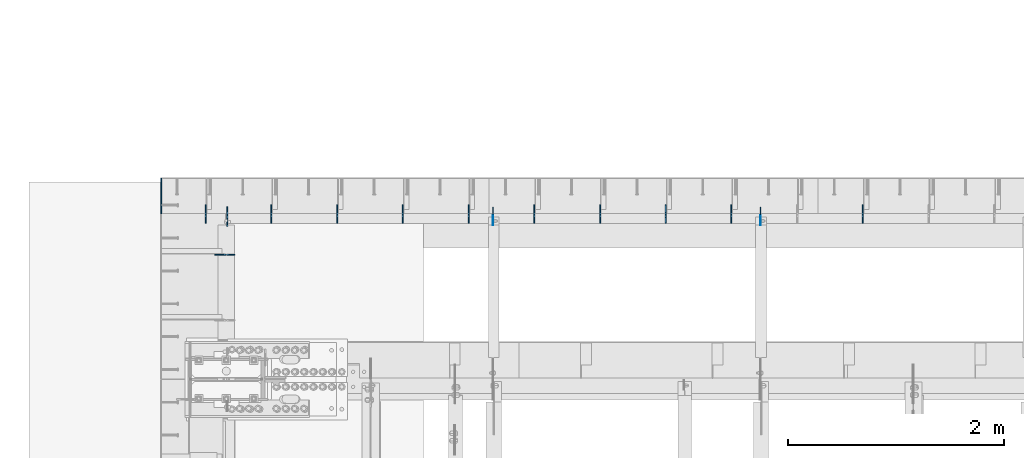
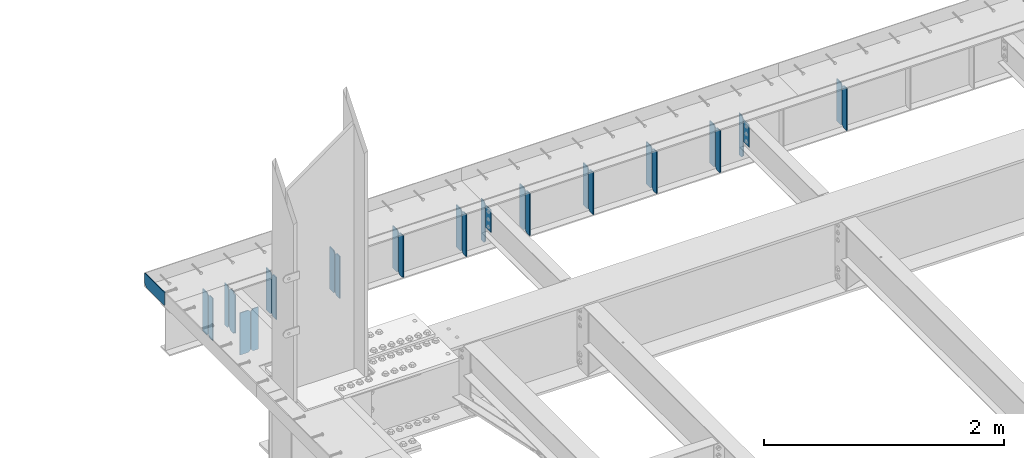
# One storey, part 1599 of 1763: 29 plates, 2 elements without a shape of their own.
"""IFC2X3 building model written with IfcOpenShell, lengths in millimetres."""

from ifc_helpers import new_model, si_unit, frame, origin_with_axes, place, context, subcontext, project, spatial, faceted_brep, material, type_object, element, aggregate, save


model = new_model("IFC2X3")

# Units and contexts
model_context = context("Model", 3, precision=1e-05, world=origin_with_axes())
body_context = subcontext(model_context, "Body", "Model", "MODEL_VIEW")
ifc_project = project(units=[si_unit("LENGTHUNIT", "METRE", prefix="MILLI"), si_unit("AREAUNIT", "SQUARE_METRE"), si_unit("VOLUMEUNIT", "CUBIC_METRE"), si_unit("MASSUNIT", "GRAM", prefix="KILO"), si_unit("TIMEUNIT", "SECOND"), si_unit("PLANEANGLEUNIT", "RADIAN"), si_unit("SOLIDANGLEUNIT", "STERADIAN"), si_unit("THERMODYNAMICTEMPERATUREUNIT", "DEGREE_CELSIUS"), si_unit("LUMINOUSINTENSITYUNIT", "LUMEN")], contexts=[model_context])

# Site, building, storey
site_placement = place(None, origin_with_axes())
site = spatial("IfcSite", under=ifc_project, at=site_placement, CompositionType="ELEMENT")
building_placement = place(site_placement, origin_with_axes())
building = spatial("IfcBuilding", under=site, at=building_placement, Name="Undefined", CompositionType="ELEMENT")
storey_placement = place(building_placement, origin_with_axes())
storey = spatial("IfcBuildingStorey", under=building, at=storey_placement, Name="Undefined", CompositionType="ELEMENT", Elevation=0.0)

# Assembly, plates
assembly_1_placement = place(storey_placement, origin_with_axes())
assembly_1 = element("IfcElementAssembly", 1, at=assembly_1_placement, inside=storey, Name="BEAM", AssemblyPlace="NOTDEFINED", PredefinedType="RIGID_FRAME")
ifc_material = material(Name="STEEL/A36")
plate_type_1 = type_object("IfcPlateType", PredefinedType="NOTDEFINED")
plate_1_placement = place(assembly_1_placement, frame((-87980.2747736984, 53657.5, 5203.825), z_axis=(0.0, 1.0, 0.0), x_axis=(0.0, 0.0, 1.0)))
plate_1 = element("IfcPlate", 2, at=plate_1_placement, type_object=plate_type_1, material=ifc_material, Name="PLATE", context=body_context, shape_type="Brep", body=[
    faceted_brep([(0.0, -4.76249999999982, 0.0), (-1.36424205265939e-11, -4.76249999999709, 301.625024795532), (-1.36424205265939e-11, 4.76249999999709, 301.625024795532), (0.0, 4.76249999999982, 0.0), (25.3999996185157, -4.76249999999709, 327.025024414062), (25.3999996185157, 4.76249999999709, 327.025024414062), (130.175003051758, -4.76249999999709, 327.025024414062), (130.175003051758, 4.76249999999709, 327.025024414062), (130.17500305171, -4.76250000028813, 3.63797880709171e-10), (130.175003051707, 4.7624999996915, 3.78349795937538e-10)], [[[0, 1, 2, 3]], [[1, 4, 5, 2]], [[4, 6, 7, 5]], [[6, 8, 9, 7]], [[8, 0, 3, 9]], [[5, 7, 9, 3, 2]], [[8, 6, 4, 1, 0]]]),
])
plate_type_2 = type_object("IfcPlateType", PredefinedType="NOTDEFINED")
plate_2_placement = place(assembly_1_placement, frame((-81470.3341486984, 53568.6, 4752.975), z_axis=(0.0, 0.0, 1.0), x_axis=(0.0, 1.0, 0.0)))
plate_2 = element("IfcPlate", 3, at=plate_2_placement, type_object=plate_type_2, material=ifc_material, Name="PLATE", context=body_context, shape_type="Brep", body=[
    faceted_brep([(0.0, -4.76249999999982, 0.0), (0.0, -4.76249999999709, 428.625), (0.0, 4.76249999999709, 428.625), (0.0, 4.76249999999982, 0.0), (53.1812477111816, -4.76249999999709, 428.625), (53.1812477111816, 4.76249999999709, 428.625), (72.2312469482422, -4.76249999999709, 409.575000762939), (72.2312469482422, 4.76249999999709, 409.575000762939), (72.2312469482422, -4.76249999999709, 19.0499992370605), (72.2312469482422, 4.76249999999709, 19.0499992370605), (53.1812477111816, -4.76249999999709, 0.0), (53.1812477111816, 4.76249999999709, 0.0)], [[[0, 1, 2, 3]], [[1, 4, 5, 2]], [[4, 6, 7, 5]], [[6, 8, 9, 7]], [[8, 10, 11, 9]], [[10, 0, 3, 11]], [[5, 7, 9, 11, 3, 2]], [[10, 8, 6, 4, 1, 0]]]),
])
plate_3_placement = place(assembly_1_placement, frame((-82689.5341486984, 53568.6, 4752.975), z_axis=(0.0, 0.0, 1.0), x_axis=(0.0, 1.0, 0.0)))
plate_3 = element("IfcPlate", 4, at=plate_3_placement, type_object=plate_type_2, material=ifc_material, Name="PLATE", context=body_context, shape_type="Brep", body=[
    faceted_brep([(0.0, -4.76249999999982, 0.0), (0.0, -4.76249999999709, 428.625), (0.0, 4.76249999999709, 428.625), (0.0, 4.76249999999982, 0.0), (53.1812477111816, -4.76249999999709, 428.625), (53.1812477111816, 4.76249999999709, 428.625), (72.2312469482422, -4.76249999999709, 409.575000762939), (72.2312469482422, 4.76249999999709, 409.575000762939), (72.2312469482422, -4.76249999999709, 19.0499992370605), (72.2312469482422, 4.76249999999709, 19.0499992370605), (53.1812477111816, -4.76249999999709, 0.0), (53.1812477111816, 4.76249999999709, 0.0)], [[[0, 1, 2, 3]], [[1, 4, 5, 2]], [[4, 6, 7, 5]], [[6, 8, 9, 7]], [[8, 10, 11, 9]], [[10, 0, 3, 11]], [[5, 7, 9, 11, 3, 2]], [[10, 8, 6, 4, 1, 0]]]),
])
plate_4_placement = place(assembly_1_placement, frame((-83299.1341486984, 53568.6, 4752.975), z_axis=(0.0, 0.0, 1.0), x_axis=(0.0, 1.0, 0.0)))
plate_4 = element("IfcPlate", 5, at=plate_4_placement, type_object=plate_type_2, material=ifc_material, Name="PLATE", context=body_context, shape_type="Brep", body=[
    faceted_brep([(0.0, -4.76249999999982, 0.0), (0.0, -4.76249999999709, 428.625), (0.0, 4.76249999999709, 428.625), (0.0, 4.76249999999982, 0.0), (53.1812477111816, -4.76249999999709, 428.625), (53.1812477111816, 4.76249999999709, 428.625), (72.2312469482422, -4.76249999999709, 409.575000762939), (72.2312469482422, 4.76249999999709, 409.575000762939), (72.2312469482422, -4.76249999999709, 19.0499992370605), (72.2312469482422, 4.76249999999709, 19.0499992370605), (53.1812477111816, -4.76249999999709, 0.0), (53.1812477111816, 4.76249999999709, 0.0)], [[[0, 1, 2, 3]], [[1, 4, 5, 2]], [[4, 6, 7, 5]], [[6, 8, 9, 7]], [[8, 10, 11, 9]], [[10, 0, 3, 11]], [[5, 7, 9, 11, 3, 2]], [[10, 8, 6, 4, 1, 0]]]),
])
plate_5_placement = place(assembly_1_placement, frame((-83908.7341486983, 53568.6, 4752.975), z_axis=(0.0, 0.0, 1.0), x_axis=(0.0, 1.0, 0.0)))
plate_5 = element("IfcPlate", 6, at=plate_5_placement, type_object=plate_type_2, material=ifc_material, Name="PLATE", context=body_context, shape_type="Brep", body=[
    faceted_brep([(0.0, -4.76249999999982, 0.0), (0.0, -4.76249999999709, 428.625), (0.0, 4.76249999999709, 428.625), (0.0, 4.76249999999982, 0.0), (53.1812477111816, -4.76249999999709, 428.625), (53.1812477111816, 4.76249999999709, 428.625), (72.2312469482422, -4.76249999999709, 409.575000762939), (72.2312469482422, 4.76249999999709, 409.575000762939), (72.2312469482422, -4.76249999999709, 19.0499992370605), (72.2312469482422, 4.76249999999709, 19.0499992370605), (53.1812477111816, -4.76249999999709, 0.0), (53.1812477111816, 4.76249999999709, 0.0)], [[[0, 1, 2, 3]], [[1, 4, 5, 2]], [[4, 6, 7, 5]], [[6, 8, 9, 7]], [[8, 10, 11, 9]], [[10, 0, 3, 11]], [[5, 7, 9, 11, 3, 2]], [[10, 8, 6, 4, 1, 0]]]),
])
plate_6_placement = place(assembly_1_placement, frame((-84518.3341486984, 53568.6, 4752.975), z_axis=(0.0, 0.0, 1.0), x_axis=(0.0, 1.0, 0.0)))
plate_6 = element("IfcPlate", 7, at=plate_6_placement, type_object=plate_type_2, material=ifc_material, Name="PLATE", context=body_context, shape_type="Brep", body=[
    faceted_brep([(0.0, -4.76249999999982, 0.0), (0.0, -4.76249999999709, 428.625), (0.0, 4.76249999999709, 428.625), (0.0, 4.76249999999982, 0.0), (53.1812477111816, -4.76249999999709, 428.625), (53.1812477111816, 4.76249999999709, 428.625), (72.2312469482422, -4.76249999999709, 409.575000762939), (72.2312469482422, 4.76249999999709, 409.575000762939), (72.2312469482422, -4.76249999999709, 19.0499992370605), (72.2312469482422, 4.76249999999709, 19.0499992370605), (53.1812477111816, -4.76249999999709, 0.0), (53.1812477111816, 4.76249999999709, 0.0)], [[[0, 1, 2, 3]], [[1, 4, 5, 2]], [[4, 6, 7, 5]], [[6, 8, 9, 7]], [[8, 10, 11, 9]], [[10, 0, 3, 11]], [[5, 7, 9, 11, 3, 2]], [[10, 8, 6, 4, 1, 0]]]),
])
plate_7_placement = place(assembly_1_placement, frame((-85127.9341486984, 53568.6, 4752.975), z_axis=(0.0, 0.0, 1.0), x_axis=(0.0, 1.0, 0.0)))
plate_7 = element("IfcPlate", 8, at=plate_7_placement, type_object=plate_type_2, material=ifc_material, Name="PLATE", context=body_context, shape_type="Brep", body=[
    faceted_brep([(0.0, -4.76249999999982, 0.0), (0.0, -4.76249999999709, 428.625), (0.0, 4.76249999999709, 428.625), (0.0, 4.76249999999982, 0.0), (53.1812477111816, -4.76249999999709, 428.625), (53.1812477111816, 4.76249999999709, 428.625), (72.2312469482422, -4.76249999999709, 409.575000762939), (72.2312469482422, 4.76249999999709, 409.575000762939), (72.2312469482422, -4.76249999999709, 19.0499992370605), (72.2312469482422, 4.76249999999709, 19.0499992370605), (53.1812477111816, -4.76249999999709, 0.0), (53.1812477111816, 4.76249999999709, 0.0)], [[[0, 1, 2, 3]], [[1, 4, 5, 2]], [[4, 6, 7, 5]], [[6, 8, 9, 7]], [[8, 10, 11, 9]], [[10, 0, 3, 11]], [[5, 7, 9, 11, 3, 2]], [[10, 8, 6, 4, 1, 0]]]),
])
plate_8_placement = place(assembly_1_placement, frame((-85737.5341486984, 53568.6, 4752.975), z_axis=(0.0, 0.0, 1.0), x_axis=(0.0, 1.0, 0.0)))
plate_8 = element("IfcPlate", 9, at=plate_8_placement, type_object=plate_type_2, material=ifc_material, Name="PLATE", context=body_context, shape_type="Brep", body=[
    faceted_brep([(0.0, -4.76249999999982, 0.0), (0.0, -4.76249999999709, 428.625), (0.0, 4.76249999999709, 428.625), (0.0, 4.76249999999982, 0.0), (53.1812477111816, -4.76249999999709, 428.625), (53.1812477111816, 4.76249999999709, 428.625), (72.2312469482422, -4.76249999999709, 409.575000762939), (72.2312469482422, 4.76249999999709, 409.575000762939), (72.2312469482422, -4.76249999999709, 19.0499992370605), (72.2312469482422, 4.76249999999709, 19.0499992370605), (53.1812477111816, -4.76249999999709, 0.0), (53.1812477111816, 4.76249999999709, 0.0)], [[[0, 1, 2, 3]], [[1, 4, 5, 2]], [[4, 6, 7, 5]], [[6, 8, 9, 7]], [[8, 10, 11, 9]], [[10, 0, 3, 11]], [[5, 7, 9, 11, 3, 2]], [[10, 8, 6, 4, 1, 0]]]),
])
plate_9_placement = place(assembly_1_placement, frame((-86347.1341486984, 53568.6, 4752.975), z_axis=(0.0, 0.0, 1.0), x_axis=(0.0, 1.0, 0.0)))
plate_9 = element("IfcPlate", 10, at=plate_9_placement, type_object=plate_type_2, material=ifc_material, Name="PLATE", context=body_context, shape_type="Brep", body=[
    faceted_brep([(0.0, -4.76249999999982, 0.0), (0.0, -4.76249999999709, 428.625), (0.0, 4.76249999999709, 428.625), (0.0, 4.76249999999982, 0.0), (53.1812477111816, -4.76249999999709, 428.625), (53.1812477111816, 4.76249999999709, 428.625), (72.2312469482422, -4.76249999999709, 409.575000762939), (72.2312469482422, 4.76249999999709, 409.575000762939), (72.2312469482422, -4.76249999999709, 19.0499992370605), (72.2312469482422, 4.76249999999709, 19.0499992370605), (53.1812477111816, -4.76249999999709, 0.0), (53.1812477111816, 4.76249999999709, 0.0)], [[[0, 1, 2, 3]], [[1, 4, 5, 2]], [[4, 6, 7, 5]], [[6, 8, 9, 7]], [[8, 10, 11, 9]], [[10, 0, 3, 11]], [[5, 7, 9, 11, 3, 2]], [[10, 8, 6, 4, 1, 0]]]),
])
plate_10_placement = place(assembly_1_placement, frame((-86956.7341486983, 53568.6, 4752.975), z_axis=(0.0, 0.0, 1.0), x_axis=(0.0, 1.0, 0.0)))
plate_10 = element("IfcPlate", 11, at=plate_10_placement, type_object=plate_type_2, material=ifc_material, Name="PLATE", context=body_context, shape_type="Brep", body=[
    faceted_brep([(0.0, -4.76249999999982, 0.0), (0.0, -4.76249999999709, 428.625), (0.0, 4.76249999999709, 428.625), (0.0, 4.76249999999982, 0.0), (53.1812477111816, -4.76249999999709, 428.625), (53.1812477111816, 4.76249999999709, 428.625), (72.2312469482422, -4.76249999999709, 409.575000762939), (72.2312469482422, 4.76249999999709, 409.575000762939), (72.2312469482422, -4.76249999999709, 19.0499992370605), (72.2312469482422, 4.76249999999709, 19.0499992370605), (53.1812477111816, -4.76249999999709, 0.0), (53.1812477111816, 4.76249999999709, 0.0)], [[[0, 1, 2, 3]], [[1, 4, 5, 2]], [[4, 6, 7, 5]], [[6, 8, 9, 7]], [[8, 10, 11, 9]], [[10, 0, 3, 11]], [[5, 7, 9, 11, 3, 2]], [[10, 8, 6, 4, 1, 0]]]),
])
plate_11_placement = place(assembly_1_placement, frame((-87566.3341486984, 53568.6, 4752.975), z_axis=(0.0, 0.0, 1.0), x_axis=(0.0, 1.0, 0.0)))
plate_11 = element("IfcPlate", 12, at=plate_11_placement, type_object=plate_type_2, material=ifc_material, Name="PLATE", context=body_context, shape_type="Brep", body=[
    faceted_brep([(0.0, -4.76249999999982, 0.0), (0.0, -4.76249999999709, 428.625), (0.0, 4.76249999999709, 428.625), (0.0, 4.76249999999982, 0.0), (53.1812477111816, -4.76249999999709, 428.625), (53.1812477111816, 4.76249999999709, 428.625), (72.2312469482422, -4.76249999999709, 409.575000762939), (72.2312469482422, 4.76249999999709, 409.575000762939), (72.2312469482422, -4.76249999999709, 19.0499992370605), (72.2312469482422, 4.76249999999709, 19.0499992370605), (53.1812477111816, -4.76249999999709, 0.0), (53.1812477111816, 4.76249999999709, 0.0)], [[[0, 1, 2, 3]], [[1, 4, 5, 2]], [[4, 6, 7, 5]], [[6, 8, 9, 7]], [[8, 10, 11, 9]], [[10, 0, 3, 11]], [[5, 7, 9, 11, 3, 2]], [[10, 8, 6, 4, 1, 0]]]),
])

# Assembly, plate
assembly_2_placement = place(storey_placement, origin_with_axes())
assembly_2 = element("IfcElementAssembly", 13, at=assembly_2_placement, inside=storey, Name="BEAM", AssemblyPlace="NOTDEFINED", PredefinedType="RIGID_FRAME")
plate_12_placement = place(assembly_2_placement, frame((-87299.2372736983, 53277.690625, 4752.975), z_axis=(0.0, 0.0, 1.0), x_axis=(-1.0, 0.0, 0.0)))
plate_12 = element("IfcPlate", 14, at=plate_12_placement, type_object=plate_type_2, material=ifc_material, Name="PLATE", context=body_context, shape_type="Brep", body=[
    faceted_brep([(0.0, -4.76249999999982, 0.0), (0.0, -4.76249999999709, 428.625), (0.0, 4.76249999999709, 428.625), (0.0, 4.76249999999982, 0.0), (53.1812477111816, -4.76249999999709, 428.625), (53.1812477111816, 4.76249999999709, 428.625), (72.2312469482422, -4.76249999999709, 409.575000762939), (72.2312469482422, 4.76249999999709, 409.575000762939), (72.2312469482422, -4.76249999999709, 19.0499992370605), (72.2312469482422, 4.76249999999709, 19.0499992370605), (53.1812477111816, -4.76249999999709, 0.0), (53.1812477111816, 4.76249999999709, 0.0)], [[[0, 1, 2, 3]], [[1, 4, 5, 2]], [[4, 6, 7, 5]], [[6, 8, 9, 7]], [[8, 10, 11, 9]], [[10, 0, 3, 11]], [[5, 7, 9, 11, 3, 2]], [[10, 8, 6, 4, 1, 0]]]),
])

# Plate
plate_13_placement = place(assembly_1_placement, frame((-87366.7055237823, 53648.76875, 4754.5625), z_axis=(0.0, 0.0, 1.0), x_axis=(0.0, 1.0, 0.0)))
plate_13 = element("IfcPlate", 15, at=plate_13_placement, type_object=plate_type_2, material=ifc_material, Name="PLATE", context=body_context, shape_type="Brep", body=[
    faceted_brep([(0.0, -4.76250000000073, 25.3999996185303), (0.0, -4.76249999999709, 400.050012588501), (0.0, 4.76249999999709, 400.050012588501), (0.0, 4.76250000000073, 25.3999996185303), (25.3999996185303, -4.76249999999709, 425.450012207031), (25.3999996185303, 4.76249999999709, 425.450012207031), (72.2312469482422, -4.76249999999709, 425.450012207031), (72.2312469482422, 4.76249999999709, 425.450012207031), (72.2312469482422, -4.76249999999709, 0.0), (72.2312469482422, 4.76249999999709, 0.0), (25.3999996185303, -4.76250000000073, 0.0), (25.3999996185303, 4.76250000000073, 0.0)], [[[0, 1, 2, 3]], [[1, 4, 5, 2]], [[4, 6, 7, 5]], [[6, 8, 9, 7]], [[8, 10, 11, 9]], [[10, 0, 3, 11]], [[5, 7, 9, 11, 3, 2]], [[10, 8, 6, 4, 1, 0]]]),
])

plate_type_3 = type_object("IfcPlateType", PredefinedType="NOTDEFINED")
plate_14_placement = place(assembly_1_placement, frame((-81470.3341486984, 53648.76875, 4752.975), z_axis=(0.0, 0.0, 1.0), x_axis=(0.0, 1.0, 0.0)))
plate_14 = element("IfcPlate", 16, at=plate_14_placement, type_object=plate_type_3, material=ifc_material, Name="PLATE", context=body_context, shape_type="Brep", body=[
    faceted_brep([(6.96272763889283e-08, -4.76249999999709, 19.0499992370605), (0.0, -4.76249999999709, 409.575000762939), (0.0, 4.76249999999709, 409.575000762939), (6.96454662829638e-08, 4.76249999999709, 19.0499992370605), (19.0499992370605, -4.76249999999709, 428.625), (19.0499992370605, 4.76249999999709, 428.625), (89.6937484741211, -4.76249999999709, 428.625), (89.6937484741211, 4.76249999999709, 428.625), (89.6937484741211, -4.76249999999709, 0.0), (89.6937484741211, 4.76249999999709, 0.0), (19.0499992370533, -4.76249999996799, -2.09183781407773e-11), (19.0499992370678, 4.76250000003347, -2.09183781407773e-11)], [[[0, 1, 2, 3]], [[1, 4, 5, 2]], [[4, 6, 7, 5]], [[6, 8, 9, 7]], [[8, 10, 11, 9]], [[10, 0, 3, 11]], [[5, 7, 9, 11, 3, 2]], [[10, 8, 6, 4, 1, 0]]]),
])

plate_15_placement = place(assembly_1_placement, frame((-82689.5341486984, 53648.76875, 4752.975), z_axis=(0.0, 0.0, 1.0), x_axis=(0.0, 1.0, 0.0)))
plate_15 = element("IfcPlate", 17, at=plate_15_placement, type_object=plate_type_3, material=ifc_material, Name="PLATE", context=body_context, shape_type="Brep", body=[
    faceted_brep([(6.96272763889283e-08, -4.76249999999709, 19.0499992370605), (0.0, -4.76249999999709, 409.575000762939), (0.0, 4.76249999999709, 409.575000762939), (6.96454662829638e-08, 4.76249999999709, 19.0499992370605), (19.0499992370605, -4.76249999999709, 428.625), (19.0499992370605, 4.76249999999709, 428.625), (89.6937484741211, -4.76249999999709, 428.625), (89.6937484741211, 4.76249999999709, 428.625), (89.6937484741211, -4.76249999999709, 0.0), (89.6937484741211, 4.76249999999709, 0.0), (19.0499992370533, -4.76249999996799, -2.09183781407773e-11), (19.0499992370678, 4.76250000003347, -2.09183781407773e-11)], [[[0, 1, 2, 3]], [[1, 4, 5, 2]], [[4, 6, 7, 5]], [[6, 8, 9, 7]], [[8, 10, 11, 9]], [[10, 0, 3, 11]], [[5, 7, 9, 11, 3, 2]], [[10, 8, 6, 4, 1, 0]]]),
])

plate_16_placement = place(assembly_1_placement, frame((-83299.1341486984, 53648.76875, 4752.975), z_axis=(0.0, 0.0, 1.0), x_axis=(0.0, 1.0, 0.0)))
plate_16 = element("IfcPlate", 18, at=plate_16_placement, type_object=plate_type_3, material=ifc_material, Name="PLATE", context=body_context, shape_type="Brep", body=[
    faceted_brep([(6.96272763889283e-08, -4.76249999999709, 19.0499992370605), (0.0, -4.76249999999709, 409.575000762939), (0.0, 4.76249999999709, 409.575000762939), (6.96454662829638e-08, 4.76249999999709, 19.0499992370605), (19.0499992370605, -4.76249999999709, 428.625), (19.0499992370605, 4.76249999999709, 428.625), (89.6937484741211, -4.76249999999709, 428.625), (89.6937484741211, 4.76249999999709, 428.625), (89.6937484741211, -4.76249999999709, 0.0), (89.6937484741211, 4.76249999999709, 0.0), (19.0499992370533, -4.76249999996799, -2.09183781407773e-11), (19.0499992370678, 4.76250000003347, -2.09183781407773e-11)], [[[0, 1, 2, 3]], [[1, 4, 5, 2]], [[4, 6, 7, 5]], [[6, 8, 9, 7]], [[8, 10, 11, 9]], [[10, 0, 3, 11]], [[5, 7, 9, 11, 3, 2]], [[10, 8, 6, 4, 1, 0]]]),
])

plate_17_placement = place(assembly_1_placement, frame((-83908.7341486983, 53648.76875, 4752.975), z_axis=(0.0, 0.0, 1.0), x_axis=(0.0, 1.0, 0.0)))
plate_17 = element("IfcPlate", 19, at=plate_17_placement, type_object=plate_type_3, material=ifc_material, Name="PLATE", context=body_context, shape_type="Brep", body=[
    faceted_brep([(6.96272763889283e-08, -4.76249999999709, 19.0499992370605), (0.0, -4.76249999999709, 409.575000762939), (0.0, 4.76249999999709, 409.575000762939), (6.96454662829638e-08, 4.76249999999709, 19.0499992370605), (19.0499992370605, -4.76249999999709, 428.625), (19.0499992370605, 4.76249999999709, 428.625), (89.6937484741211, -4.76249999999709, 428.625), (89.6937484741211, 4.76249999999709, 428.625), (89.6937484741211, -4.76249999999709, 0.0), (89.6937484741211, 4.76249999999709, 0.0), (19.0499992370533, -4.76249999996799, -2.09183781407773e-11), (19.0499992370678, 4.76250000003347, -2.09183781407773e-11)], [[[0, 1, 2, 3]], [[1, 4, 5, 2]], [[4, 6, 7, 5]], [[6, 8, 9, 7]], [[8, 10, 11, 9]], [[10, 0, 3, 11]], [[5, 7, 9, 11, 3, 2]], [[10, 8, 6, 4, 1, 0]]]),
])

plate_18_placement = place(assembly_1_placement, frame((-84518.3341486984, 53648.76875, 4752.975), z_axis=(0.0, 0.0, 1.0), x_axis=(0.0, 1.0, 0.0)))
plate_18 = element("IfcPlate", 20, at=plate_18_placement, type_object=plate_type_3, material=ifc_material, Name="PLATE", context=body_context, shape_type="Brep", body=[
    faceted_brep([(6.96272763889283e-08, -4.76249999999709, 19.0499992370605), (0.0, -4.76249999999709, 409.575000762939), (0.0, 4.76249999999709, 409.575000762939), (6.96454662829638e-08, 4.76249999999709, 19.0499992370605), (19.0499992370605, -4.76249999999709, 428.625), (19.0499992370605, 4.76249999999709, 428.625), (89.6937484741211, -4.76249999999709, 428.625), (89.6937484741211, 4.76249999999709, 428.625), (89.6937484741211, -4.76249999999709, 0.0), (89.6937484741211, 4.76249999999709, 0.0), (19.0499992370533, -4.76249999996799, -2.09183781407773e-11), (19.0499992370678, 4.76250000003347, -2.09183781407773e-11)], [[[0, 1, 2, 3]], [[1, 4, 5, 2]], [[4, 6, 7, 5]], [[6, 8, 9, 7]], [[8, 10, 11, 9]], [[10, 0, 3, 11]], [[5, 7, 9, 11, 3, 2]], [[10, 8, 6, 4, 1, 0]]]),
])

plate_19_placement = place(assembly_1_placement, frame((-85127.9341486984, 53648.76875, 4752.975), z_axis=(0.0, 0.0, 1.0), x_axis=(0.0, 1.0, 0.0)))
plate_19 = element("IfcPlate", 21, at=plate_19_placement, type_object=plate_type_3, material=ifc_material, Name="PLATE", context=body_context, shape_type="Brep", body=[
    faceted_brep([(6.96272763889283e-08, -4.76249999999709, 19.0499992370605), (0.0, -4.76249999999709, 409.575000762939), (0.0, 4.76249999999709, 409.575000762939), (6.96454662829638e-08, 4.76249999999709, 19.0499992370605), (19.0499992370605, -4.76249999999709, 428.625), (19.0499992370605, 4.76249999999709, 428.625), (89.6937484741211, -4.76249999999709, 428.625), (89.6937484741211, 4.76249999999709, 428.625), (89.6937484741211, -4.76249999999709, 0.0), (89.6937484741211, 4.76249999999709, 0.0), (19.0499992370533, -4.76249999996799, -2.09183781407773e-11), (19.0499992370678, 4.76250000003347, -2.09183781407773e-11)], [[[0, 1, 2, 3]], [[1, 4, 5, 2]], [[4, 6, 7, 5]], [[6, 8, 9, 7]], [[8, 10, 11, 9]], [[10, 0, 3, 11]], [[5, 7, 9, 11, 3, 2]], [[10, 8, 6, 4, 1, 0]]]),
])

plate_20_placement = place(assembly_1_placement, frame((-85737.5341486984, 53648.76875, 4752.975), z_axis=(0.0, 0.0, 1.0), x_axis=(0.0, 1.0, 0.0)))
plate_20 = element("IfcPlate", 22, at=plate_20_placement, type_object=plate_type_3, material=ifc_material, Name="PLATE", context=body_context, shape_type="Brep", body=[
    faceted_brep([(6.96272763889283e-08, -4.76249999999709, 19.0499992370605), (0.0, -4.76249999999709, 409.575000762939), (0.0, 4.76249999999709, 409.575000762939), (6.96454662829638e-08, 4.76249999999709, 19.0499992370605), (19.0499992370605, -4.76249999999709, 428.625), (19.0499992370605, 4.76249999999709, 428.625), (89.6937484741211, -4.76249999999709, 428.625), (89.6937484741211, 4.76249999999709, 428.625), (89.6937484741211, -4.76249999999709, 0.0), (89.6937484741211, 4.76249999999709, 0.0), (19.0499992370533, -4.76249999996799, -2.09183781407773e-11), (19.0499992370678, 4.76250000003347, -2.09183781407773e-11)], [[[0, 1, 2, 3]], [[1, 4, 5, 2]], [[4, 6, 7, 5]], [[6, 8, 9, 7]], [[8, 10, 11, 9]], [[10, 0, 3, 11]], [[5, 7, 9, 11, 3, 2]], [[10, 8, 6, 4, 1, 0]]]),
])

plate_21_placement = place(assembly_1_placement, frame((-86347.1341486984, 53648.76875, 4752.975), z_axis=(0.0, 0.0, 1.0), x_axis=(0.0, 1.0, 0.0)))
plate_21 = element("IfcPlate", 23, at=plate_21_placement, type_object=plate_type_3, material=ifc_material, Name="PLATE", context=body_context, shape_type="Brep", body=[
    faceted_brep([(6.96272763889283e-08, -4.76249999999709, 19.0499992370605), (0.0, -4.76249999999709, 409.575000762939), (0.0, 4.76249999999709, 409.575000762939), (6.96454662829638e-08, 4.76249999999709, 19.0499992370605), (19.0499992370605, -4.76249999999709, 428.625), (19.0499992370605, 4.76249999999709, 428.625), (89.6937484741211, -4.76249999999709, 428.625), (89.6937484741211, 4.76249999999709, 428.625), (89.6937484741211, -4.76249999999709, 0.0), (89.6937484741211, 4.76249999999709, 0.0), (19.0499992370533, -4.76249999996799, -2.09183781407773e-11), (19.0499992370678, 4.76250000003347, -2.09183781407773e-11)], [[[0, 1, 2, 3]], [[1, 4, 5, 2]], [[4, 6, 7, 5]], [[6, 8, 9, 7]], [[8, 10, 11, 9]], [[10, 0, 3, 11]], [[5, 7, 9, 11, 3, 2]], [[10, 8, 6, 4, 1, 0]]]),
])

plate_22_placement = place(assembly_1_placement, frame((-86956.7341486983, 53648.76875, 4752.975), z_axis=(0.0, 0.0, 1.0), x_axis=(0.0, 1.0, 0.0)))
plate_22 = element("IfcPlate", 24, at=plate_22_placement, type_object=plate_type_3, material=ifc_material, Name="PLATE", context=body_context, shape_type="Brep", body=[
    faceted_brep([(6.96272763889283e-08, -4.76249999999709, 19.0499992370605), (0.0, -4.76249999999709, 409.575000762939), (0.0, 4.76249999999709, 409.575000762939), (6.96454662829638e-08, 4.76249999999709, 19.0499992370605), (19.0499992370605, -4.76249999999709, 428.625), (19.0499992370605, 4.76249999999709, 428.625), (89.6937484741211, -4.76249999999709, 428.625), (89.6937484741211, 4.76249999999709, 428.625), (89.6937484741211, -4.76249999999709, 0.0), (89.6937484741211, 4.76249999999709, 0.0), (19.0499992370533, -4.76249999996799, -2.09183781407773e-11), (19.0499992370678, 4.76250000003347, -2.09183781407773e-11)], [[[0, 1, 2, 3]], [[1, 4, 5, 2]], [[4, 6, 7, 5]], [[6, 8, 9, 7]], [[8, 10, 11, 9]], [[10, 0, 3, 11]], [[5, 7, 9, 11, 3, 2]], [[10, 8, 6, 4, 1, 0]]]),
])

plate_23_placement = place(assembly_1_placement, frame((-87566.3341486984, 53648.76875, 4752.975), z_axis=(0.0, 0.0, 1.0), x_axis=(0.0, 1.0, 0.0)))
plate_23 = element("IfcPlate", 25, at=plate_23_placement, type_object=plate_type_3, material=ifc_material, Name="PLATE", context=body_context, shape_type="Brep", body=[
    faceted_brep([(6.96272763889283e-08, -4.76249999999709, 19.0499992370605), (0.0, -4.76249999999709, 409.575000762939), (0.0, 4.76249999999709, 409.575000762939), (6.96454662829638e-08, 4.76249999999709, 19.0499992370605), (19.0499992370605, -4.76249999999709, 428.625), (19.0499992370605, 4.76249999999709, 428.625), (89.6937484741211, -4.76249999999709, 428.625), (89.6937484741211, 4.76249999999709, 428.625), (89.6937484741211, -4.76249999999709, 0.0), (89.6937484741211, 4.76249999999709, 0.0), (19.0499992370533, -4.76249999996799, -2.09183781407773e-11), (19.0499992370678, 4.76250000003347, -2.09183781407773e-11)], [[[0, 1, 2, 3]], [[1, 4, 5, 2]], [[4, 6, 7, 5]], [[6, 8, 9, 7]], [[8, 10, 11, 9]], [[10, 0, 3, 11]], [[5, 7, 9, 11, 3, 2]], [[10, 8, 6, 4, 1, 0]]]),
])

plate_type_4 = type_object("IfcPlateType", PredefinedType="NOTDEFINED")
plate_24_placement = place(assembly_1_placement, frame((-87366.7055237823, 53640.83125, 4754.5625), z_axis=(0.0, 0.0, 1.0), x_axis=(0.0, -1.0, 0.0)))
plate_24 = element("IfcPlate", 26, at=plate_24_placement, type_object=plate_type_4, material=ifc_material, Name="PLATE", context=body_context, shape_type="Brep", body=[
    faceted_brep([(72.2312469482422, -4.76249999999709, 0.0), (72.2312469482422, 4.76249999999709, 0.0), (72.2312469482422, 4.76249999999709, 6.3499994277945), (72.2312469482422, -4.76249999999709, 6.3499994277945), (73.1979768708334, 4.76249999999709, 11.21007894584), (73.1979768708334, -4.76249999999709, 11.21007894584), (75.9509907713073, 4.76249999999709, 15.3302554139937), (75.9509907713073, -4.76249999999709, 15.3302554139937), (80.0711672394609, 4.76249999999709, 18.0832693144721), (80.0711672394609, -4.76249999999709, 18.0832693144721), (84.9312467575073, 4.76249999999709, 19.0499992370596), (84.9312467575073, -4.76249999999709, 19.0499992370596), (98.4250030517433, -4.76249999999709, 19.0499992370605), (98.4250030517578, 4.76249999999709, 19.0499992370605), (25.3999996185303, -4.76250000000073, 0.0), (0.0, -4.76250000000073, 25.3999996185303), (0.0, 4.76250000000073, 25.3999996185303), (25.3999996185303, 4.76250000000073, 0.0), (0.0, -4.76249999999709, 401.637506484985), (0.0, 4.76249999999709, 401.637506484985), (25.3999996185303, -4.76249999999709, 427.037506103516), (25.3999996185303, 4.76249999999709, 427.037506103516), (72.2312469482422, -4.76249999999709, 427.037506103516), (72.2312469482422, 4.76249999999709, 427.037506103516), (72.2312469482276, -4.76249999999709, 420.687499809273), (72.2312469482276, 4.76249999999709, 420.687499809273), (73.1979768708188, -4.76249999999709, 415.827420291227), (73.1979768708188, 4.76249999999709, 415.827420291227), (75.9509907712927, -4.76249999999709, 411.707243823073), (75.9509907712927, 4.76249999999709, 411.707243823073), (80.0711672394464, -4.76249999999709, 408.954229922595), (80.0711672394464, 4.76249999999709, 408.954229922595), (84.9312467574928, -4.76249999999709, 407.987500000007), (84.9312467574928, 4.76249999999709, 407.987500000007), (98.4250030517433, -4.76249999999709, 407.987500000007), (98.4250030517578, 4.76249999999709, 407.987500000007)], [[[0, 1, 2, 3]], [[3, 2, 4, 5]], [[5, 4, 6, 7]], [[7, 6, 8, 9]], [[9, 8, 10, 11]], [[12, 11, 10, 13]], [[14, 15, 16, 17]], [[15, 18, 19, 16]], [[18, 20, 21, 19]], [[21, 20, 22, 23]], [[22, 24, 25, 23]], [[26, 27, 25, 24]], [[28, 29, 27, 26]], [[30, 31, 29, 28]], [[32, 33, 31, 30]], [[34, 35, 33, 32]], [[35, 34, 12, 13]], [[8, 6, 4, 2, 1, 17, 16, 19, 21, 23, 25, 27, 29, 31, 33, 35, 13, 10]], [[0, 14, 17, 1]], [[34, 32, 30, 28, 26, 24, 22, 20, 18, 15, 14, 0, 3, 5, 7, 9, 11, 12]]]),
])

plate_type_5 = type_object("IfcPlateType", PredefinedType="NOTDEFINED")
plate_25_placement = place(assembly_2_placement, frame((-87379.4060236983, 53277.690625, 4752.975), z_axis=(0.0, 0.0, 1.0), x_axis=(-1.0, 0.0, 0.0)))
plate_25 = element("IfcPlate", 27, at=plate_25_placement, type_object=plate_type_5, material=ifc_material, Name="PLATE", context=body_context, shape_type="Brep", body=[
    faceted_brep([(6.96272763889283e-08, -4.76249999999709, 19.0499992370605), (0.0, -4.76249999999709, 409.575000762939), (0.0, 4.76249999999709, 409.575000762939), (6.96454662829638e-08, 4.76249999999709, 19.0499992370605), (19.0499992370605, -4.76249999999709, 428.625), (19.0499992370605, 4.76249999999709, 428.625), (100.806251525879, -4.76249999999709, 428.625), (100.806251525879, 4.76249999999709, 428.625), (100.806251525879, -4.76249999999709, 0.0), (100.806251525879, 4.76249999999709, 0.0), (19.0499992370533, -4.76249999996799, -2.09183781407773e-11), (19.0499992370678, 4.76250000003347, -2.09183781407773e-11)], [[[0, 1, 2, 3]], [[1, 4, 5, 2]], [[4, 6, 7, 5]], [[6, 8, 9, 7]], [[8, 10, 11, 9]], [[10, 0, 3, 11]], [[5, 7, 9, 11, 3, 2]], [[10, 8, 6, 4, 1, 0]]]),
])

aggregate(assembly_2, [plate_12, plate_25])

plate_type_6 = type_object("IfcPlateType", PredefinedType="NOTDEFINED")
plate_26_placement = place(assembly_1_placement, frame((-82420.3206070317, 53640.83125, 5156.2), z_axis=(0.0, -1.0, 0.0), x_axis=(0.0, 0.0, -1.0)))
plate_26 = element("IfcPlate", 28, at=plate_26_placement, type_object=plate_type_6, material=ifc_material, Name="PLATE", context=body_context, shape_type="Brep", body=[
    faceted_brep([(1.81898940354586e-12, -3.17500000000291, 0.0), (0.0, -3.17499999999927, 88.9000015258789), (0.0, 3.17499999999927, 88.9000015258789), (-1.81898940354586e-12, 3.17499999997381, 0.0), (228.600006103516, -3.17499999999927, 88.9000015258789), (228.600006103516, 3.17499999999927, 88.9000015258789), (228.600006103516, -3.17500000001019, -7.27595761418343e-12), (228.600006103516, 3.17499999999563, -7.27595761418343e-12)], [[[0, 1, 2, 3]], [[1, 4, 5, 2]], [[4, 6, 7, 5]], [[6, 0, 3, 7]], [[5, 7, 3, 2]], [[6, 4, 1, 0]]]),
])

plate_27_placement = place(assembly_1_placement, frame((-84901.053940365, 53640.83125, 5156.2), z_axis=(0.0, -1.0, 0.0), x_axis=(0.0, 0.0, -1.0)))
plate_27 = element("IfcPlate", 29, at=plate_27_placement, type_object=plate_type_6, material=ifc_material, Name="PLATE", context=body_context, shape_type="Brep", body=[
    faceted_brep([(1.81898940354586e-12, -3.17500000000291, 0.0), (0.0, -3.17499999999927, 88.9000015258789), (0.0, 3.17499999999927, 88.9000015258789), (-1.81898940354586e-12, 3.17499999997381, 0.0), (228.600006103516, -3.17499999999927, 88.9000015258789), (228.600006103516, 3.17499999999927, 88.9000015258789), (228.600006103516, -3.17500000001019, -7.27595761418343e-12), (228.600006103516, 3.17499999999563, -7.27595761418343e-12)], [[[0, 1, 2, 3]], [[1, 4, 5, 2]], [[4, 6, 7, 5]], [[6, 0, 3, 7]], [[5, 7, 3, 2]], [[6, 4, 1, 0]]]),
])

plate_type_7 = type_object("IfcPlateType", PredefinedType="NOTDEFINED")
plate_28_placement = place(assembly_1_placement, frame((-82420.3206070794, 53648.76875, 4754.5625), z_axis=(0.0, 0.0, 1.0), x_axis=(0.0, 1.0, 0.0)))
plate_28 = element("IfcPlate", 30, at=plate_28_placement, type_object=plate_type_7, material=ifc_material, Name="PLATE", context=body_context, shape_type="Brep", body=[
    faceted_brep([(0.0, -3.17499999987194, 25.4000000001051), (0.0, -3.17500000000291, 400.050012588501), (0.0, 3.17500000000291, 400.050012588501), (0.0, 3.17500000014843, 25.4000000001197), (25.3999996185303, -3.17500000000291, 425.450012207031), (25.3999996185303, 3.17500000000291, 425.450012207031), (69.8499984741211, -3.17500000000291, 425.450012207031), (69.8499984741211, 3.17500000000291, 425.450012207031), (69.8499984741211, -3.17500000000291, 0.0), (69.8499984741211, 3.17500000000291, 0.0), (25.3999996184939, -3.17499999996653, 1.2732925824821e-11), (25.3999996185303, 3.17499995230901, 0.0)], [[[0, 1, 2, 3]], [[1, 4, 5, 2]], [[4, 6, 7, 5]], [[6, 8, 9, 7]], [[8, 10, 11, 9]], [[10, 0, 3, 11]], [[5, 7, 9, 11, 3, 2]], [[10, 8, 6, 4, 1, 0]]]),
])

plate_29_placement = place(assembly_1_placement, frame((-84901.0539404127, 53648.76875, 4754.5625), z_axis=(0.0, 0.0, 1.0), x_axis=(0.0, 1.0, 0.0)))
plate_29 = element("IfcPlate", 31, at=plate_29_placement, type_object=plate_type_7, material=ifc_material, Name="PLATE", context=body_context, shape_type="Brep", body=[
    faceted_brep([(0.0, -3.17499999987194, 25.4000000001051), (0.0, -3.17500000000291, 400.050012588501), (0.0, 3.17500000000291, 400.050012588501), (0.0, 3.17500000014843, 25.4000000001197), (25.3999996185303, -3.17500000000291, 425.450012207031), (25.3999996185303, 3.17500000000291, 425.450012207031), (69.8499984741211, -3.17500000000291, 425.450012207031), (69.8499984741211, 3.17500000000291, 425.450012207031), (69.8499984741211, -3.17500000000291, 0.0), (69.8499984741211, 3.17500000000291, 0.0), (25.3999996184939, -3.17499999996653, 1.2732925824821e-11), (25.3999996185303, 3.17499995230901, 0.0)], [[[0, 1, 2, 3]], [[1, 4, 5, 2]], [[4, 6, 7, 5]], [[6, 8, 9, 7]], [[8, 10, 11, 9]], [[10, 0, 3, 11]], [[5, 7, 9, 11, 3, 2]], [[10, 8, 6, 4, 1, 0]]]),
])

aggregate(assembly_1, [plate_2, plate_14, plate_3, plate_15, plate_4, plate_16, plate_5, plate_17, plate_6, plate_18, plate_7, plate_19, plate_8, plate_20, plate_9, plate_21, plate_10, plate_22, plate_11, plate_23, plate_1, plate_28, plate_26, plate_29, plate_27, plate_13, plate_24])

save(model, "model.ifc")
